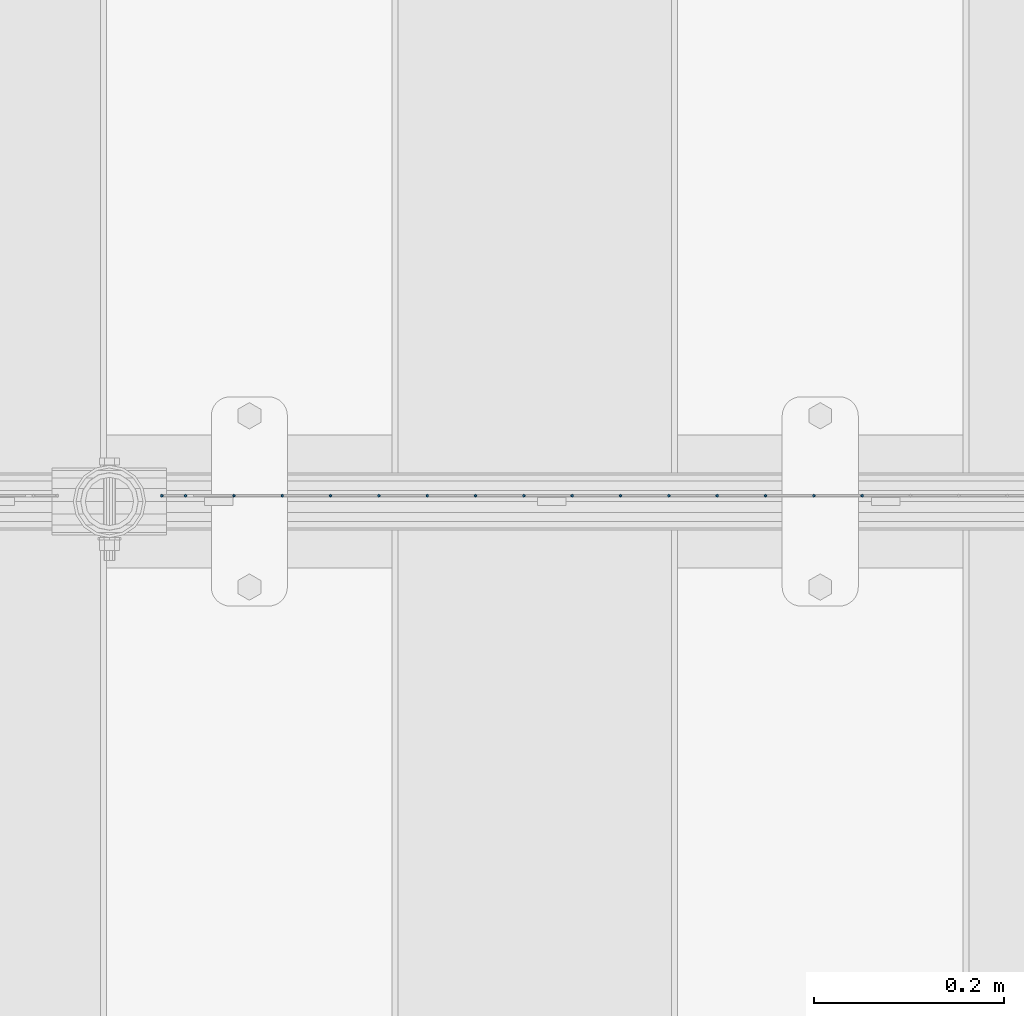
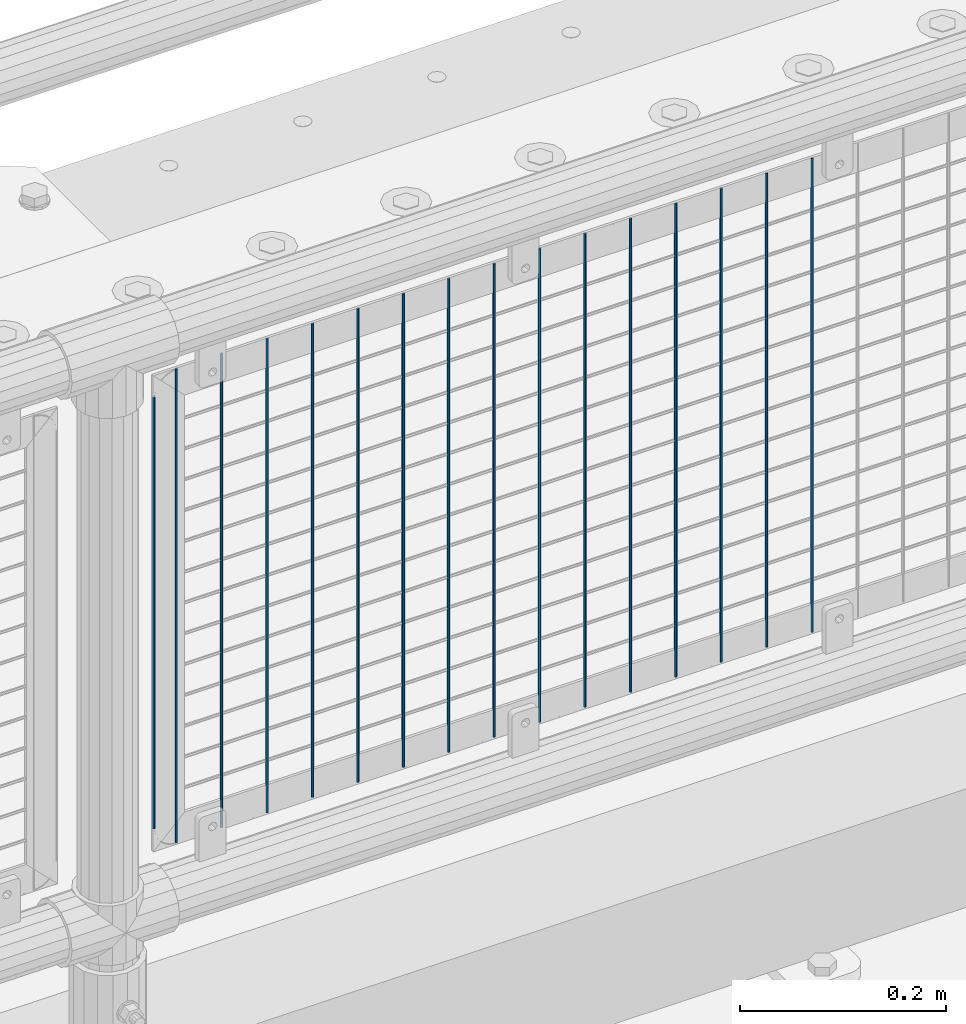
# One storey, part 82 of 270: 16 columns.
"""IFC2X3 building model written with IfcOpenShell, lengths in millimetres."""

from ifc_helpers import new_model, si_unit, frame, origin_with_axes, place, context, subcontext, project, spatial, faceted_brep, material, type_object, element, save


model = new_model("IFC2X3")

# Units and contexts
model_context = context("Model", 3, precision=1e-05, world=origin_with_axes())
body_context = subcontext(model_context, "Body", "Model", "MODEL_VIEW")
ifc_project = project(units=[si_unit("LENGTHUNIT", "METRE", prefix="MILLI"), si_unit("AREAUNIT", "SQUARE_METRE"), si_unit("VOLUMEUNIT", "CUBIC_METRE"), si_unit("MASSUNIT", "GRAM", prefix="KILO"), si_unit("TIMEUNIT", "SECOND"), si_unit("PLANEANGLEUNIT", "RADIAN"), si_unit("SOLIDANGLEUNIT", "STERADIAN"), si_unit("THERMODYNAMICTEMPERATUREUNIT", "DEGREE_CELSIUS"), si_unit("LUMINOUSINTENSITYUNIT", "LUMEN")], contexts=[model_context])

# Site, building, storey
site_placement = place(None, origin_with_axes())
site = spatial("IfcSite", under=ifc_project, at=site_placement, CompositionType="ELEMENT")
building_placement = place(site_placement, origin_with_axes())
building = spatial("IfcBuilding", under=site, at=building_placement, Name="Standard", CompositionType="ELEMENT")
storey_placement = place(building_placement, origin_with_axes())
storey = spatial("IfcBuildingStorey", under=building, at=storey_placement, Name="Undefined", CompositionType="ELEMENT", Elevation=0.0)

# Columns
ifc_material = material(Name="Misc_Undefined")
column_type = type_object("IfcColumnType", Name="D3", PredefinedType="NOTDEFINED")
for number, where, z_axis, x_axis in (
    (1, (7944.102, -16329.5, 353.02), (-1.0, 0.0, 0.0), (0.0, 0.0, 1.0)),
    (2, (7893.309, -16329.5, 353.02), (-1.0, 0.0, 0.0), (0.0, 0.0, 1.0)),
    (3, (7842.516, -16329.5, 353.02), (-1.0, 0.0, 0.0), (0.0, 0.0, 1.0)),
    (4, (7791.723, -16329.5, 353.02), (-1.0, 0.0, 0.0), (0.0, 0.0, 1.0)),
    (5, (7740.93, -16329.5, 353.02), (-1.0, 0.0, 0.0), (0.0, 0.0, 1.0)),
    (6, (7690.137, -16329.5, 353.02), (-1.0, 0.0, 0.0), (0.0, 0.0, 1.0)),
    (7, (7639.344, -16329.5, 353.02), (-1.0, 0.0, 0.0), (0.0, 0.0, 1.0)),
    (8, (7588.551, -16329.5, 353.02), (-1.0, 0.0, 0.0), (0.0, 0.0, 1.0)),
    (9, (7537.758, -16329.5, 353.02), (-1.0, 0.0, 0.0), (0.0, 0.0, 1.0)),
    (10, (7486.965, -16329.5, 353.02), (-1.0, 0.0, 0.0), (0.0, 0.0, 1.0)),
    (11, (7436.172, -16329.5, 353.02), (-1.0, 0.0, 0.0), (0.0, 0.0, 1.0)),
    (12, (7385.379, -16329.5, 353.02), (-1.0, 0.0, 0.0), (0.0, 0.0, 1.0)),
    (13, (7334.586, -16329.5, 353.02), (-1.0, 0.0, 0.0), (0.0, 0.0, 1.0)),
    (14, (7283.793, -16329.5, 353.02), (-1.0, 0.0, 0.0), (0.0, 0.0, 1.0)),
):
    element("IfcColumn", number, at=place(storey_placement, frame(where, z_axis=z_axis, x_axis=x_axis)), inside=storey, type_object=column_type, material=ifc_material, ObjectType="D3", context=body_context, shape_type="Brep", body=[
        faceted_brep([(0.0, -1.5, 0.0), (0.0, -0.75, -1.29903810567669), (560.0, -0.75, -1.29903810567703), (560.0, -1.5, 0.0), (0.0, 0.75, -1.29903810567669), (560.0, 0.75, -1.29903810567703), (0.0, 1.5, 0.0), (560.0, 1.5, 0.0), (0.0, 0.75, 1.29903810567669), (560.0, 0.75, 1.29903810567703), (0.0, -0.75, 1.29903810567669), (560.0, -0.75, 1.29903810567703)], [[[0, 1, 2, 3]], [[1, 4, 5, 2]], [[4, 6, 7, 5]], [[6, 8, 9, 7]], [[8, 10, 11, 9]], [[10, 0, 3, 11]], [[5, 7, 9, 11, 3, 2]], [[10, 8, 6, 4, 1, 0]]]),
    ])
column_1_placement = place(storey_placement, frame((7208.0, -16329.5, 378.02), z_axis=(-1.0, 0.0, 0.0), x_axis=(0.0, 0.0, 1.0)))
element("IfcColumn", 15, at=column_1_placement, inside=storey, type_object=column_type, material=ifc_material, ObjectType="D3", context=body_context, shape_type="Brep", body=[
    faceted_brep([(0.0, -1.5, 0.0), (0.0, -0.75, -1.29903810567669), (510.0, -0.75, -1.29903810567703), (510.0, -1.5, 0.0), (0.0, 0.75, -1.29903810567669), (510.0, 0.75, -1.29903810567703), (0.0, 1.5, 0.0), (510.0, 1.5, 0.0), (0.0, 0.75, 1.29903810567669), (510.0, 0.75, 1.29903810567703), (0.0, -0.75, 1.29903810567669), (510.0, -0.75, 1.29903810567703)], [[[0, 1, 2, 3]], [[1, 4, 5, 2]], [[4, 6, 7, 5]], [[6, 8, 9, 7]], [[8, 10, 11, 9]], [[10, 0, 3, 11]], [[5, 7, 9, 11, 3, 2]], [[10, 8, 6, 4, 1, 0]]]),
])
column_2_placement = place(storey_placement, frame((7233.0, -16329.5, 353.02), z_axis=(-1.0, 0.0, 0.0), x_axis=(0.0, 0.0, 1.0)))
element("IfcColumn", 16, at=column_2_placement, inside=storey, type_object=column_type, material=ifc_material, ObjectType="D3", context=body_context, shape_type="Brep", body=[
    faceted_brep([(0.0, -1.5, 0.0), (0.0, -0.75, -1.29903810567669), (560.0, -0.75, -1.29903810567703), (560.0, -1.5, 0.0), (0.0, 0.75, -1.29903810567669), (560.0, 0.75, -1.29903810567703), (0.0, 1.5, 0.0), (560.0, 1.5, 0.0), (0.0, 0.75, 1.29903810567669), (560.0, 0.75, 1.29903810567703), (0.0, -0.75, 1.29903810567669), (560.0, -0.75, 1.29903810567703)], [[[0, 1, 2, 3]], [[1, 4, 5, 2]], [[4, 6, 7, 5]], [[6, 8, 9, 7]], [[8, 10, 11, 9]], [[10, 0, 3, 11]], [[5, 7, 9, 11, 3, 2]], [[10, 8, 6, 4, 1, 0]]]),
])

save(model, "model.ifc")
